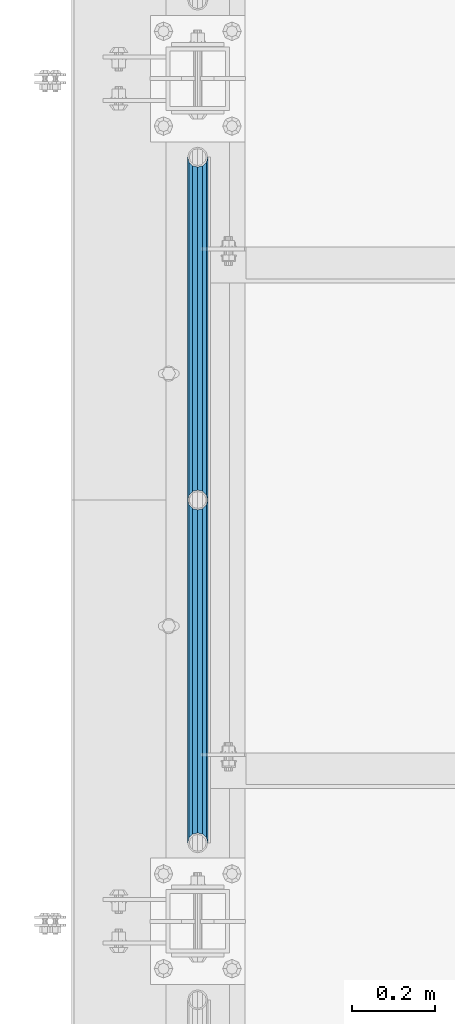
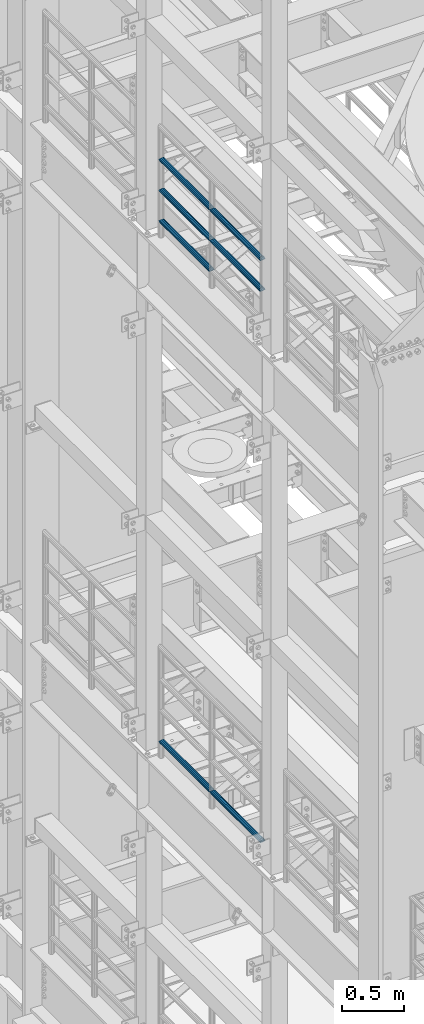
# One storey, part 1227 of 1876: 7 beams, 2 elements without a shape of their own.
"""IFC2X3 building model written with IfcOpenShell, lengths in millimetres."""

from ifc_helpers import new_model, si_unit, frame, origin_with_axes, place, context, subcontext, project, spatial, faceted_brep, material, type_object, element, aggregate, save


model = new_model("IFC2X3")

# Units and contexts
model_context = context("Model", 3, precision=1e-05, world=origin_with_axes())
body_context = subcontext(model_context, "Body", "Model", "MODEL_VIEW")
ifc_project = project(units=[si_unit("LENGTHUNIT", "METRE", prefix="MILLI"), si_unit("AREAUNIT", "SQUARE_METRE"), si_unit("VOLUMEUNIT", "CUBIC_METRE"), si_unit("MASSUNIT", "GRAM", prefix="KILO"), si_unit("TIMEUNIT", "SECOND"), si_unit("PLANEANGLEUNIT", "RADIAN"), si_unit("SOLIDANGLEUNIT", "STERADIAN"), si_unit("THERMODYNAMICTEMPERATUREUNIT", "DEGREE_CELSIUS"), si_unit("LUMINOUSINTENSITYUNIT", "LUMEN")], contexts=[model_context])

# Site, building, storey
site_placement = place(None, origin_with_axes())
site = spatial("IfcSite", under=ifc_project, at=site_placement, CompositionType="ELEMENT")
building_placement = place(site_placement, origin_with_axes())
building = spatial("IfcBuilding", under=site, at=building_placement, Name="Undefined", CompositionType="ELEMENT")
storey_placement = place(building_placement, origin_with_axes())
storey = spatial("IfcBuildingStorey", under=building, at=storey_placement, Name="Undefined", CompositionType="ELEMENT", Elevation=0.0)

# Assembly, beams
assembly_1_placement = place(storey_placement, origin_with_axes())
assembly_1 = element("IfcElementAssembly", 1, at=assembly_1_placement, inside=storey, Name="RAIL", AssemblyPlace="NOTDEFINED", PredefinedType="RIGID_FRAME")
ifc_material = material()
beam_type = type_object("IfcBeamType", Name="PIPE1-1/2SCH40", PredefinedType="NOTDEFINED")
beam_1_placement = place(assembly_1_placement, frame((-1.81898940354586e-12, -697.230000000001, 13471.525), z_axis=(0.0, 0.0, 1.0), x_axis=(0.0, -1.0, 0.0)))
beam_1 = element("IfcBeam", 2, at=beam_1_placement, type_object=beam_type, material=ifc_material, Name="RAIL", ObjectType="PIPE1-1/2SCH40", context=body_context, shape_type="Brep", body=[
    faceted_brep([(805.872807006681, -12.0649999999996, 20.8971929933177), (805.872807006683, -12.0649999999996, 15.8661214311796), (805.379378568819, -10.2235000000001, 17.7076214311819), (802.640000000001, 0.0, 20.4470000000001), (802.640000000001, 0.0, 24.130000000001), (805.379378568819, 10.2235000000001, 17.7076214311819), (805.872807006683, 12.0649999999996, 15.8661214311796), (805.872807006681, 12.0649999999996, 20.8971929933177), (826.77, 24.1300000000001, 0.0), (814.705, 20.8971929933186, 12.0649999999987), (814.705, 20.8971929933186, -12.0649999999987), (811.515428437862, 17.7076214311801, 10.2235000000001), (814.254807006682, 20.4470000000001, 0.0), (811.515428437862, 17.7076214311801, -10.2235000000001), (805.872807006683, 12.0649999999996, -15.8661214311796), (805.872807006681, 12.0649999999996, -20.8971929933177), (805.379378568819, 10.2235000000001, -17.7076214311819), (802.640000000001, 0.0, -20.4470000000001), (802.640000000001, 0.0, -24.130000000001), (805.872807006683, -12.0649999999996, -15.8661214311796), (805.872807006681, -12.0649999999996, -20.8971929933177), (805.379378568819, -10.2235000000001, -17.7076214311819), (826.77, -24.1300000000001, 0.0), (814.705, -20.8971929933186, -12.0649999999987), (814.705, -20.8971929933186, 12.0649999999987), (811.515428437862, -17.7076214311801, -10.2235000000001), (814.254807006682, -20.4470000000001, 0.0), (811.515428437862, -17.7076214311801, 10.2235000000001), (12.0650000000064, -20.8971929933177, -12.0649999999987), (20.8971929933249, -12.0650000000005, -20.8971929933177), (0.0, 24.1299999999992, 0.0), (12.0650000000064, 20.8971929933177, -12.0649999999987), (12.0650000000064, 20.8971929933177, 12.0649999999987), (20.8971929933249, 12.0650000000005, 20.8971929933177), (24.1300000000064, 0.0, 24.130000000001), (20.8971929933249, 12.0650000000005, -20.8971929933177), (24.1300000000063, 0.0, -24.130000000001), (24.1300000000063, 0.0, -20.4470000000001), (20.8971929933249, -12.0650000000005, -15.8661214311796), (21.3906214311868, -10.2235000000001, -17.7076214311819), (21.3906214311868, 10.2235000000001, -17.7076214311819), (20.8971929933249, 12.0650000000005, -15.8661214311796), (15.2545715621445, 17.7076214311801, -10.2235000000001), (12.5151929933249, 20.4470000000001, 0.0), (15.2545715621445, 17.7076214311801, 10.2235000000001), (20.8971929933249, 12.0650000000005, 15.8661214311796), (21.3906214311868, 10.2235000000001, 17.7076214311819), (24.1300000000064, 0.0, 20.4470000000001), (21.3906214311868, -10.2235000000001, 17.7076214311819), (20.8971929933249, -12.0650000000005, 15.8661214311796), (20.8971929933249, -12.0650000000005, 20.8971929933177), (12.0650000000064, -20.8971929933177, 12.0649999999987), (0.0, -24.1299999999992, 0.0), (15.2545715621445, -17.7076214311801, 10.2235000000001), (12.5151929933249, -20.4470000000001, 0.0), (15.2545715621445, -17.7076214311801, -10.2235000000001)], [[[0, 1, 2, 3, 4]], [[4, 3, 5, 6, 7]], [[8, 9, 10]], [[7, 6, 11, 12, 13, 14, 15, 10, 9]], [[16, 17, 18, 15, 14]], [[19, 20, 18, 17, 21]], [[22, 23, 24]], [[24, 23, 20, 19, 25, 26, 27, 1, 0]], [[28, 29, 20, 23]], [[30, 31, 32]], [[33, 34, 4, 7]], [[32, 33, 7, 9]], [[30, 32, 9, 8]], [[31, 30, 8, 10]], [[35, 31, 10, 15]], [[36, 35, 15, 18]], [[29, 36, 18, 20]], [[37, 36, 29, 38, 39]], [[40, 41, 35, 36, 37]], [[32, 31, 35, 41, 42, 43, 44, 45, 33]], [[33, 45, 46, 47, 34]], [[34, 47, 48, 49, 50]], [[34, 50, 0, 4]], [[50, 51, 24, 0]], [[51, 52, 22, 24]], [[52, 28, 23, 22]], [[51, 28, 52]], [[50, 49, 53, 54, 55, 38, 29, 28, 51]], [[55, 54, 26, 25]], [[21, 39, 38, 55, 25, 19]], [[37, 39, 21, 17]], [[40, 37, 17, 16]], [[42, 41, 40, 16, 14, 13]], [[43, 42, 13, 12]], [[44, 43, 12, 11]], [[5, 46, 45, 44, 11, 6]], [[47, 46, 5, 3]], [[48, 47, 3, 2]], [[53, 49, 48, 2, 1, 27]], [[54, 53, 27, 26]]]),
])
beam_2_placement = place(assembly_1_placement, frame((-1.81898940354586e-12, -2350.77, 13776.325), z_axis=(0.0, 0.0, -1.0), x_axis=(0.0, 1.0, 0.0)))
beam_2 = element("IfcBeam", 3, at=beam_2_placement, type_object=beam_type, material=ifc_material, Name="RAIL", ObjectType="PIPE1-1/2SCH40", context=body_context, shape_type="Brep", body=[
    faceted_brep([(0.0, 24.1299999999992, 0.0), (12.0650000000064, 20.8971929933177, -12.0649999999987), (12.0650000000064, 20.8971929933177, 12.0649999999987), (12.0650000000064, -20.8971929933177, 12.0649999999987), (12.0650000000064, -20.8971929933177, -12.0649999999987), (0.0, -24.1299999999992, 0.0), (20.8971929933249, -12.0650000000005, 20.8971929933177), (20.8971929933249, -12.0650000000005, 15.8661214311796), (15.2545715621445, -17.7076214311801, 10.2235000000001), (12.5151929933249, -20.4470000000001, 0.0), (15.2545715621445, -17.7076214311801, -10.2235000000001), (20.8971929933249, -12.0650000000005, -15.8661214311796), (20.8971929933249, -12.0650000000005, -20.8971929933177), (24.1300000000063, 0.0, -20.4470000000001), (24.1300000000063, 0.0, -24.130000000001), (21.3906214311868, -10.2235000000001, -17.7076214311819), (21.3906214311868, 10.2235000000001, -17.7076214311819), (20.8971929933249, 12.0650000000005, -15.8661214311796), (20.8971929933249, 12.0650000000005, -20.8971929933177), (15.2545715621445, 17.7076214311801, -10.2235000000001), (12.5151929933249, 20.4470000000001, 0.0), (15.2545715621445, 17.7076214311801, 10.2235000000001), (20.8971929933249, 12.0650000000005, 15.8661214311796), (20.8971929933249, 12.0650000000005, 20.8971929933177), (21.3906214311868, 10.2235000000001, 17.7076214311819), (24.1300000000064, 0.0, 20.4470000000001), (24.1300000000064, 0.0, 24.130000000001), (21.3906214311868, -10.2235000000001, 17.7076214311819), (826.77, 24.1300000000001, 0.0), (814.705, 20.8971929933186, -12.0649999999987), (805.872807006681, 12.0649999999996, -20.8971929933177), (826.77, -24.1300000000001, 0.0), (814.705, -20.8971929933186, -12.0649999999987), (814.705, -20.8971929933186, 12.0649999999987), (805.872807006681, -12.0649999999996, 20.8971929933177), (805.872807006681, -12.0649999999996, -20.8971929933177), (802.640000000001, 0.0, -24.130000000001), (805.379378568819, 10.2235000000001, -17.7076214311819), (802.640000000001, 0.0, -20.4470000000001), (805.872807006683, 12.0649999999996, -15.8661214311796), (805.872807006683, -12.0649999999996, -15.8661214311796), (805.379378568819, -10.2235000000001, -17.7076214311819), (811.515428437862, -17.7076214311801, -10.2235000000001), (814.254807006682, -20.4470000000001, 0.0), (811.515428437862, -17.7076214311801, 10.2235000000001), (805.872807006683, -12.0649999999996, 15.8661214311796), (805.379378568819, -10.2235000000001, 17.7076214311819), (802.640000000001, 0.0, 20.4470000000001), (802.640000000001, 0.0, 24.130000000001), (805.872807006681, 12.0649999999996, 20.8971929933177), (814.705, 20.8971929933186, 12.0649999999987), (805.872807006683, 12.0649999999996, 15.8661214311796), (811.515428437862, 17.7076214311801, 10.2235000000001), (814.254807006682, 20.4470000000001, 0.0), (811.515428437862, 17.7076214311801, -10.2235000000001), (805.379378568819, 10.2235000000001, 17.7076214311819)], [[[0, 1, 2]], [[3, 4, 5]], [[6, 7, 8, 9, 10, 11, 12, 4, 3]], [[13, 14, 12, 11, 15]], [[16, 17, 18, 14, 13]], [[2, 1, 18, 17, 19, 20, 21, 22, 23]], [[23, 22, 24, 25, 26]], [[26, 25, 27, 7, 6]], [[1, 0, 28, 29]], [[18, 1, 29, 30]], [[31, 32, 33]], [[6, 3, 33, 34]], [[3, 5, 31, 33]], [[5, 4, 32, 31]], [[4, 12, 35, 32]], [[12, 14, 36, 35]], [[14, 18, 30, 36]], [[37, 38, 36, 30, 39]], [[40, 35, 36, 38, 41]], [[33, 32, 35, 40, 42, 43, 44, 45, 34]], [[34, 45, 46, 47, 48]], [[26, 6, 34, 48]], [[2, 23, 49, 50]], [[23, 26, 48, 49]], [[0, 2, 50, 28]], [[28, 50, 29]], [[49, 51, 52, 53, 54, 39, 30, 29, 50]], [[48, 47, 55, 51, 49]], [[25, 24, 55, 47]], [[55, 24, 22, 21, 52, 51]], [[21, 20, 53, 52]], [[20, 19, 54, 53]], [[19, 17, 16, 37, 39, 54]], [[16, 13, 38, 37]], [[13, 15, 41, 38]], [[41, 15, 11, 10, 42, 40]], [[10, 9, 43, 42]], [[9, 8, 44, 43]], [[8, 7, 27, 46, 45, 44]], [[27, 25, 47, 46]]]),
])
beam_3_placement = place(assembly_1_placement, frame((-1.81898940354586e-12, -1524.0, 13776.325), z_axis=(0.0, 0.0, -1.0), x_axis=(0.0, 1.0, 0.0)))
beam_3 = element("IfcBeam", 4, at=beam_3_placement, type_object=beam_type, material=ifc_material, Name="RAIL", ObjectType="PIPE1-1/2SCH40", context=body_context, shape_type="Brep", body=[
    faceted_brep([(0.0, 24.1299999999992, 0.0), (12.0650000000064, 20.8971929933177, -12.0649999999987), (12.0650000000064, 20.8971929933177, 12.0649999999987), (12.0650000000064, -20.8971929933177, 12.0649999999987), (12.0650000000064, -20.8971929933177, -12.0649999999987), (0.0, -24.1299999999992, 0.0), (20.8971929933249, -12.0650000000005, 20.8971929933177), (20.8971929933249, -12.0650000000005, 15.8661214311796), (15.2545715621445, -17.7076214311801, 10.2235000000001), (12.5151929933249, -20.4470000000001, 0.0), (15.2545715621445, -17.7076214311801, -10.2235000000001), (20.8971929933249, -12.0650000000005, -15.8661214311796), (20.8971929933249, -12.0650000000005, -20.8971929933177), (24.1300000000063, 0.0, -20.4470000000001), (24.1300000000063, 0.0, -24.130000000001), (21.3906214311868, -10.2235000000001, -17.7076214311819), (21.3906214311868, 10.2235000000001, -17.7076214311819), (20.8971929933249, 12.0650000000005, -15.8661214311796), (20.8971929933249, 12.0650000000005, -20.8971929933177), (15.2545715621445, 17.7076214311801, -10.2235000000001), (12.5151929933249, 20.4470000000001, 0.0), (15.2545715621445, 17.7076214311801, 10.2235000000001), (20.8971929933249, 12.0650000000005, 15.8661214311796), (20.8971929933249, 12.0650000000005, 20.8971929933177), (21.3906214311868, 10.2235000000001, 17.7076214311819), (24.1300000000064, 0.0, 20.4470000000001), (24.1300000000064, 0.0, 24.130000000001), (21.3906214311868, -10.2235000000001, 17.7076214311819), (826.77, 24.1300000000001, 0.0), (814.705, 20.8971929933186, -12.0649999999987), (805.872807006681, 12.0649999999996, -20.8971929933177), (826.77, -24.1300000000001, 0.0), (814.705, -20.8971929933186, -12.0649999999987), (814.705, -20.8971929933186, 12.0649999999987), (805.872807006681, -12.0649999999996, 20.8971929933177), (805.872807006681, -12.0649999999996, -20.8971929933177), (802.640000000001, 0.0, -24.130000000001), (805.379378568819, 10.2235000000001, -17.7076214311819), (802.640000000001, 0.0, -20.4470000000001), (805.872807006683, 12.0649999999996, -15.8661214311796), (805.872807006683, -12.0649999999996, -15.8661214311796), (805.379378568819, -10.2235000000001, -17.7076214311819), (811.515428437862, -17.7076214311801, -10.2235000000001), (814.254807006682, -20.4470000000001, 0.0), (811.515428437862, -17.7076214311801, 10.2235000000001), (805.872807006683, -12.0649999999996, 15.8661214311796), (805.379378568819, -10.2235000000001, 17.7076214311819), (802.640000000001, 0.0, 20.4470000000001), (802.640000000001, 0.0, 24.130000000001), (805.872807006681, 12.0649999999996, 20.8971929933177), (814.705, 20.8971929933186, 12.0649999999987), (805.872807006683, 12.0649999999996, 15.8661214311796), (811.515428437862, 17.7076214311801, 10.2235000000001), (814.254807006682, 20.4470000000001, 0.0), (811.515428437862, 17.7076214311801, -10.2235000000001), (805.379378568819, 10.2235000000001, 17.7076214311819)], [[[0, 1, 2]], [[3, 4, 5]], [[6, 7, 8, 9, 10, 11, 12, 4, 3]], [[13, 14, 12, 11, 15]], [[16, 17, 18, 14, 13]], [[2, 1, 18, 17, 19, 20, 21, 22, 23]], [[23, 22, 24, 25, 26]], [[26, 25, 27, 7, 6]], [[1, 0, 28, 29]], [[18, 1, 29, 30]], [[31, 32, 33]], [[6, 3, 33, 34]], [[3, 5, 31, 33]], [[5, 4, 32, 31]], [[4, 12, 35, 32]], [[12, 14, 36, 35]], [[14, 18, 30, 36]], [[37, 38, 36, 30, 39]], [[40, 35, 36, 38, 41]], [[33, 32, 35, 40, 42, 43, 44, 45, 34]], [[34, 45, 46, 47, 48]], [[26, 6, 34, 48]], [[2, 23, 49, 50]], [[23, 26, 48, 49]], [[0, 2, 50, 28]], [[28, 50, 29]], [[49, 51, 52, 53, 54, 39, 30, 29, 50]], [[48, 47, 55, 51, 49]], [[25, 24, 55, 47]], [[55, 24, 22, 21, 52, 51]], [[21, 20, 53, 52]], [[20, 19, 54, 53]], [[19, 17, 16, 37, 39, 54]], [[16, 13, 38, 37]], [[13, 15, 41, 38]], [[41, 15, 11, 10, 42, 40]], [[10, 9, 43, 42]], [[9, 8, 44, 43]], [[8, 7, 27, 46, 45, 44]], [[27, 25, 47, 46]]]),
])
beam_4_placement = place(assembly_1_placement, frame((-1.81898940354586e-12, -2350.77, 14081.125), z_axis=(0.0, 0.0, -1.0), x_axis=(0.0, 1.0, 0.0)))
beam_4 = element("IfcBeam", 5, at=beam_4_placement, type_object=beam_type, material=ifc_material, Name="RAIL", ObjectType="PIPE1-1/2SCH40", context=body_context, shape_type="Brep", body=[
    faceted_brep([(0.0, 24.1299999999992, 0.0), (12.0650000000064, 20.8971929933177, -12.0649999999987), (12.0650000000064, 20.8971929933177, 12.0649999999987), (12.0650000000064, -20.8971929933177, 12.0649999999987), (12.0650000000064, -20.8971929933177, -12.0649999999987), (0.0, -24.1299999999992, 0.0), (20.8971929933249, -12.0650000000005, 20.8971929933177), (20.8971929933249, -12.0650000000005, 15.8661214311796), (15.2545715621445, -17.7076214311801, 10.2235000000001), (12.5151929933249, -20.4470000000001, 0.0), (15.2545715621445, -17.7076214311801, -10.2235000000001), (20.8971929933249, -12.0650000000005, -15.8661214311796), (20.8971929933249, -12.0650000000005, -20.8971929933177), (24.1300000000063, 0.0, -20.4470000000001), (24.1300000000063, 0.0, -24.130000000001), (21.3906214311868, -10.2235000000001, -17.7076214311819), (21.3906214311868, 10.2235000000001, -17.7076214311819), (20.8971929933249, 12.0650000000005, -15.8661214311796), (20.8971929933249, 12.0650000000005, -20.8971929933177), (15.2545715621445, 17.7076214311801, -10.2235000000001), (12.5151929933249, 20.4470000000001, 0.0), (15.2545715621445, 17.7076214311801, 10.2235000000001), (20.8971929933249, 12.0650000000005, 15.8661214311796), (20.8971929933249, 12.0650000000005, 20.8971929933177), (21.3906214311868, 10.2235000000001, 17.7076214311819), (24.1300000000064, 0.0, 20.4470000000001), (24.1300000000064, 0.0, 24.130000000001), (21.3906214311868, -10.2235000000001, 17.7076214311819), (826.77, 24.1300000000001, 0.0), (814.705, 20.8971929933186, -12.0649999999987), (805.872807006681, 12.0649999999996, -20.8971929933177), (826.77, -24.1300000000001, 0.0), (814.705, -20.8971929933186, -12.0649999999987), (814.705, -20.8971929933186, 12.0649999999987), (805.872807006681, -12.0649999999996, 20.8971929933177), (805.872807006681, -12.0649999999996, -20.8971929933177), (802.640000000001, 0.0, -24.130000000001), (805.379378568819, 10.2235000000001, -17.7076214311819), (802.640000000001, 0.0, -20.4470000000001), (805.872807006683, 12.0649999999996, -15.8661214311796), (805.872807006683, -12.0649999999996, -15.8661214311796), (805.379378568819, -10.2235000000001, -17.7076214311819), (811.515428437862, -17.7076214311801, -10.2235000000001), (814.254807006682, -20.4470000000001, 0.0), (811.515428437862, -17.7076214311801, 10.2235000000001), (805.872807006683, -12.0649999999996, 15.8661214311796), (805.379378568819, -10.2235000000001, 17.7076214311819), (802.640000000001, 0.0, 20.4470000000001), (802.640000000001, 0.0, 24.130000000001), (805.872807006681, 12.0649999999996, 20.8971929933177), (814.705, 20.8971929933186, 12.0649999999987), (805.872807006683, 12.0649999999996, 15.8661214311796), (811.515428437862, 17.7076214311801, 10.2235000000001), (814.254807006682, 20.4470000000001, 0.0), (811.515428437862, 17.7076214311801, -10.2235000000001), (805.379378568819, 10.2235000000001, 17.7076214311819)], [[[0, 1, 2]], [[3, 4, 5]], [[6, 7, 8, 9, 10, 11, 12, 4, 3]], [[13, 14, 12, 11, 15]], [[16, 17, 18, 14, 13]], [[2, 1, 18, 17, 19, 20, 21, 22, 23]], [[23, 22, 24, 25, 26]], [[26, 25, 27, 7, 6]], [[1, 0, 28, 29]], [[18, 1, 29, 30]], [[31, 32, 33]], [[6, 3, 33, 34]], [[3, 5, 31, 33]], [[5, 4, 32, 31]], [[4, 12, 35, 32]], [[12, 14, 36, 35]], [[14, 18, 30, 36]], [[37, 38, 36, 30, 39]], [[40, 35, 36, 38, 41]], [[33, 32, 35, 40, 42, 43, 44, 45, 34]], [[34, 45, 46, 47, 48]], [[26, 6, 34, 48]], [[2, 23, 49, 50]], [[23, 26, 48, 49]], [[0, 2, 50, 28]], [[28, 50, 29]], [[49, 51, 52, 53, 54, 39, 30, 29, 50]], [[48, 47, 55, 51, 49]], [[25, 24, 55, 47]], [[55, 24, 22, 21, 52, 51]], [[21, 20, 53, 52]], [[20, 19, 54, 53]], [[19, 17, 16, 37, 39, 54]], [[16, 13, 38, 37]], [[13, 15, 41, 38]], [[41, 15, 11, 10, 42, 40]], [[10, 9, 43, 42]], [[9, 8, 44, 43]], [[8, 7, 27, 46, 45, 44]], [[27, 25, 47, 46]]]),
])
beam_5_placement = place(assembly_1_placement, frame((-1.81898940354586e-12, -1524.0, 14081.125), z_axis=(0.0, 0.0, -1.0), x_axis=(0.0, 1.0, 0.0)))
beam_5 = element("IfcBeam", 6, at=beam_5_placement, type_object=beam_type, material=ifc_material, Name="RAIL", ObjectType="PIPE1-1/2SCH40", context=body_context, shape_type="Brep", body=[
    faceted_brep([(0.0, 24.1299999999992, 0.0), (12.0650000000064, 20.8971929933177, -12.0649999999987), (12.0650000000064, 20.8971929933177, 12.0649999999987), (12.0650000000064, -20.8971929933177, 12.0649999999987), (12.0650000000064, -20.8971929933177, -12.0649999999987), (0.0, -24.1299999999992, 0.0), (20.8971929933249, -12.0650000000005, 20.8971929933177), (20.8971929933249, -12.0650000000005, 15.8661214311796), (15.2545715621445, -17.7076214311801, 10.2235000000001), (12.5151929933249, -20.4470000000001, 0.0), (15.2545715621445, -17.7076214311801, -10.2235000000001), (20.8971929933249, -12.0650000000005, -15.8661214311796), (20.8971929933249, -12.0650000000005, -20.8971929933177), (24.1300000000063, 0.0, -20.4470000000001), (24.1300000000063, 0.0, -24.130000000001), (21.3906214311868, -10.2235000000001, -17.7076214311819), (21.3906214311868, 10.2235000000001, -17.7076214311819), (20.8971929933249, 12.0650000000005, -15.8661214311796), (20.8971929933249, 12.0650000000005, -20.8971929933177), (15.2545715621445, 17.7076214311801, -10.2235000000001), (12.5151929933249, 20.4470000000001, 0.0), (15.2545715621445, 17.7076214311801, 10.2235000000001), (20.8971929933249, 12.0650000000005, 15.8661214311796), (20.8971929933249, 12.0650000000005, 20.8971929933177), (21.3906214311868, 10.2235000000001, 17.7076214311819), (24.1300000000064, 0.0, 20.4470000000001), (24.1300000000064, 0.0, 24.130000000001), (21.3906214311868, -10.2235000000001, 17.7076214311819), (826.77, 24.1300000000001, 0.0), (814.705, 20.8971929933186, -12.0649999999987), (805.872807006681, 12.0649999999996, -20.8971929933177), (826.77, -24.1300000000001, 0.0), (814.705, -20.8971929933186, -12.0649999999987), (814.705, -20.8971929933186, 12.0649999999987), (805.872807006681, -12.0649999999996, 20.8971929933177), (805.872807006681, -12.0649999999996, -20.8971929933177), (802.640000000001, 0.0, -24.130000000001), (805.379378568819, 10.2235000000001, -17.7076214311819), (802.640000000001, 0.0, -20.4470000000001), (805.872807006683, 12.0649999999996, -15.8661214311796), (805.872807006683, -12.0649999999996, -15.8661214311796), (805.379378568819, -10.2235000000001, -17.7076214311819), (811.515428437862, -17.7076214311801, -10.2235000000001), (814.254807006682, -20.4470000000001, 0.0), (811.515428437862, -17.7076214311801, 10.2235000000001), (805.872807006683, -12.0649999999996, 15.8661214311796), (805.379378568819, -10.2235000000001, 17.7076214311819), (802.640000000001, 0.0, 20.4470000000001), (802.640000000001, 0.0, 24.130000000001), (805.872807006681, 12.0649999999996, 20.8971929933177), (814.705, 20.8971929933186, 12.0649999999987), (805.872807006683, 12.0649999999996, 15.8661214311796), (811.515428437862, 17.7076214311801, 10.2235000000001), (814.254807006682, 20.4470000000001, 0.0), (811.515428437862, 17.7076214311801, -10.2235000000001), (805.379378568819, 10.2235000000001, 17.7076214311819)], [[[0, 1, 2]], [[3, 4, 5]], [[6, 7, 8, 9, 10, 11, 12, 4, 3]], [[13, 14, 12, 11, 15]], [[16, 17, 18, 14, 13]], [[2, 1, 18, 17, 19, 20, 21, 22, 23]], [[23, 22, 24, 25, 26]], [[26, 25, 27, 7, 6]], [[1, 0, 28, 29]], [[18, 1, 29, 30]], [[31, 32, 33]], [[6, 3, 33, 34]], [[3, 5, 31, 33]], [[5, 4, 32, 31]], [[4, 12, 35, 32]], [[12, 14, 36, 35]], [[14, 18, 30, 36]], [[37, 38, 36, 30, 39]], [[40, 35, 36, 38, 41]], [[33, 32, 35, 40, 42, 43, 44, 45, 34]], [[34, 45, 46, 47, 48]], [[26, 6, 34, 48]], [[2, 23, 49, 50]], [[23, 26, 48, 49]], [[0, 2, 50, 28]], [[28, 50, 29]], [[49, 51, 52, 53, 54, 39, 30, 29, 50]], [[48, 47, 55, 51, 49]], [[25, 24, 55, 47]], [[55, 24, 22, 21, 52, 51]], [[21, 20, 53, 52]], [[20, 19, 54, 53]], [[19, 17, 16, 37, 39, 54]], [[16, 13, 38, 37]], [[13, 15, 41, 38]], [[41, 15, 11, 10, 42, 40]], [[10, 9, 43, 42]], [[9, 8, 44, 43]], [[8, 7, 27, 46, 45, 44]], [[27, 25, 47, 46]]]),
])
aggregate(assembly_1, [beam_1, beam_2, beam_3, beam_4, beam_5])

assembly_2_placement = place(storey_placement, origin_with_axes())
assembly_2 = element("IfcElementAssembly", 7, at=assembly_2_placement, inside=storey, Name="RAIL", AssemblyPlace="NOTDEFINED", PredefinedType="RIGID_FRAME")
beam_6_placement = place(assembly_2_placement, frame((-1.81898940354586e-12, -1524.0, 8315.325), z_axis=(0.0, 0.0, 1.0), x_axis=(0.0, -1.0, 0.0)))
beam_6 = element("IfcBeam", 8, at=beam_6_placement, type_object=beam_type, material=ifc_material, Name="RAIL", ObjectType="PIPE1-1/2SCH40", context=body_context, shape_type="Brep", body=[
    faceted_brep([(805.872807006681, -12.0649999999996, 20.8971929933177), (805.872807006683, -12.0649999999996, 15.8661214311796), (805.379378568819, -10.2235000000001, 17.7076214311819), (802.640000000001, 0.0, 20.4470000000001), (802.640000000001, 0.0, 24.130000000001), (805.379378568819, 10.2235000000001, 17.7076214311819), (805.872807006683, 12.0649999999996, 15.8661214311796), (805.872807006681, 12.0649999999996, 20.8971929933177), (826.77, 24.1300000000001, 0.0), (814.705, 20.8971929933186, 12.0649999999987), (814.705, 20.8971929933186, -12.0649999999987), (811.515428437862, 17.7076214311801, 10.2235000000001), (814.254807006682, 20.4470000000001, 0.0), (811.515428437862, 17.7076214311801, -10.2235000000001), (805.872807006683, 12.0649999999996, -15.8661214311796), (805.872807006681, 12.0649999999996, -20.8971929933177), (805.379378568819, 10.2235000000001, -17.7076214311819), (802.640000000001, 0.0, -20.4470000000001), (802.640000000001, 0.0, -24.130000000001), (805.872807006683, -12.0649999999996, -15.8661214311796), (805.872807006681, -12.0649999999996, -20.8971929933177), (805.379378568819, -10.2235000000001, -17.7076214311819), (826.77, -24.1300000000001, 0.0), (814.705, -20.8971929933186, -12.0649999999987), (814.705, -20.8971929933186, 12.0649999999987), (811.515428437862, -17.7076214311801, -10.2235000000001), (814.254807006682, -20.4470000000001, 0.0), (811.515428437862, -17.7076214311801, 10.2235000000001), (12.0650000000064, -20.8971929933177, -12.0649999999987), (20.8971929933249, -12.0650000000005, -20.8971929933177), (0.0, 24.1299999999992, 0.0), (12.0650000000064, 20.8971929933177, -12.0649999999987), (12.0650000000064, 20.8971929933177, 12.0649999999987), (20.8971929933249, 12.0650000000005, 20.8971929933177), (24.1300000000064, 0.0, 24.130000000001), (20.8971929933249, 12.0650000000005, -20.8971929933177), (24.1300000000063, 0.0, -24.130000000001), (24.1300000000063, 0.0, -20.4470000000001), (20.8971929933249, -12.0650000000005, -15.8661214311796), (21.3906214311868, -10.2235000000001, -17.7076214311819), (21.3906214311868, 10.2235000000001, -17.7076214311819), (20.8971929933249, 12.0650000000005, -15.8661214311796), (15.2545715621445, 17.7076214311801, -10.2235000000001), (12.5151929933249, 20.4470000000001, 0.0), (15.2545715621445, 17.7076214311801, 10.2235000000001), (20.8971929933249, 12.0650000000005, 15.8661214311796), (21.3906214311868, 10.2235000000001, 17.7076214311819), (24.1300000000064, 0.0, 20.4470000000001), (21.3906214311868, -10.2235000000001, 17.7076214311819), (20.8971929933249, -12.0650000000005, 15.8661214311796), (20.8971929933249, -12.0650000000005, 20.8971929933177), (12.0650000000064, -20.8971929933177, 12.0649999999987), (0.0, -24.1299999999992, 0.0), (15.2545715621445, -17.7076214311801, 10.2235000000001), (12.5151929933249, -20.4470000000001, 0.0), (15.2545715621445, -17.7076214311801, -10.2235000000001)], [[[0, 1, 2, 3, 4]], [[4, 3, 5, 6, 7]], [[8, 9, 10]], [[7, 6, 11, 12, 13, 14, 15, 10, 9]], [[16, 17, 18, 15, 14]], [[19, 20, 18, 17, 21]], [[22, 23, 24]], [[24, 23, 20, 19, 25, 26, 27, 1, 0]], [[28, 29, 20, 23]], [[30, 31, 32]], [[33, 34, 4, 7]], [[32, 33, 7, 9]], [[30, 32, 9, 8]], [[31, 30, 8, 10]], [[35, 31, 10, 15]], [[36, 35, 15, 18]], [[29, 36, 18, 20]], [[37, 36, 29, 38, 39]], [[40, 41, 35, 36, 37]], [[32, 31, 35, 41, 42, 43, 44, 45, 33]], [[33, 45, 46, 47, 34]], [[34, 47, 48, 49, 50]], [[34, 50, 0, 4]], [[50, 51, 24, 0]], [[51, 52, 22, 24]], [[52, 28, 23, 22]], [[51, 28, 52]], [[50, 49, 53, 54, 55, 38, 29, 28, 51]], [[55, 54, 26, 25]], [[21, 39, 38, 55, 25, 19]], [[37, 39, 21, 17]], [[40, 37, 17, 16]], [[42, 41, 40, 16, 14, 13]], [[43, 42, 13, 12]], [[44, 43, 12, 11]], [[5, 46, 45, 44, 11, 6]], [[47, 46, 5, 3]], [[48, 47, 3, 2]], [[53, 49, 48, 2, 1, 27]], [[54, 53, 27, 26]]]),
])
beam_7_placement = place(assembly_2_placement, frame((-1.81898940354586e-12, -697.230000000001, 8315.325), z_axis=(0.0, 0.0, 1.0), x_axis=(0.0, -1.0, 0.0)))
beam_7 = element("IfcBeam", 9, at=beam_7_placement, type_object=beam_type, material=ifc_material, Name="RAIL", ObjectType="PIPE1-1/2SCH40", context=body_context, shape_type="Brep", body=[
    faceted_brep([(805.872807006681, -12.0649999999996, 20.8971929933177), (805.872807006683, -12.0649999999996, 15.8661214311796), (805.379378568819, -10.2235000000001, 17.7076214311819), (802.640000000001, 0.0, 20.4470000000001), (802.640000000001, 0.0, 24.130000000001), (805.379378568819, 10.2235000000001, 17.7076214311819), (805.872807006683, 12.0649999999996, 15.8661214311796), (805.872807006681, 12.0649999999996, 20.8971929933177), (826.77, 24.1300000000001, 0.0), (814.705, 20.8971929933186, 12.0649999999987), (814.705, 20.8971929933186, -12.0649999999987), (811.515428437862, 17.7076214311801, 10.2235000000001), (814.254807006682, 20.4470000000001, 0.0), (811.515428437862, 17.7076214311801, -10.2235000000001), (805.872807006683, 12.0649999999996, -15.8661214311796), (805.872807006681, 12.0649999999996, -20.8971929933177), (805.379378568819, 10.2235000000001, -17.7076214311819), (802.640000000001, 0.0, -20.4470000000001), (802.640000000001, 0.0, -24.130000000001), (805.872807006683, -12.0649999999996, -15.8661214311796), (805.872807006681, -12.0649999999996, -20.8971929933177), (805.379378568819, -10.2235000000001, -17.7076214311819), (826.77, -24.1300000000001, 0.0), (814.705, -20.8971929933186, -12.0649999999987), (814.705, -20.8971929933186, 12.0649999999987), (811.515428437862, -17.7076214311801, -10.2235000000001), (814.254807006682, -20.4470000000001, 0.0), (811.515428437862, -17.7076214311801, 10.2235000000001), (12.0650000000064, -20.8971929933177, -12.0649999999987), (20.8971929933249, -12.0650000000005, -20.8971929933177), (0.0, 24.1299999999992, 0.0), (12.0650000000064, 20.8971929933177, -12.0649999999987), (12.0650000000064, 20.8971929933177, 12.0649999999987), (20.8971929933249, 12.0650000000005, 20.8971929933177), (24.1300000000064, 0.0, 24.130000000001), (20.8971929933249, 12.0650000000005, -20.8971929933177), (24.1300000000063, 0.0, -24.130000000001), (24.1300000000063, 0.0, -20.4470000000001), (20.8971929933249, -12.0650000000005, -15.8661214311796), (21.3906214311868, -10.2235000000001, -17.7076214311819), (21.3906214311868, 10.2235000000001, -17.7076214311819), (20.8971929933249, 12.0650000000005, -15.8661214311796), (15.2545715621445, 17.7076214311801, -10.2235000000001), (12.5151929933249, 20.4470000000001, 0.0), (15.2545715621445, 17.7076214311801, 10.2235000000001), (20.8971929933249, 12.0650000000005, 15.8661214311796), (21.3906214311868, 10.2235000000001, 17.7076214311819), (24.1300000000064, 0.0, 20.4470000000001), (21.3906214311868, -10.2235000000001, 17.7076214311819), (20.8971929933249, -12.0650000000005, 15.8661214311796), (20.8971929933249, -12.0650000000005, 20.8971929933177), (12.0650000000064, -20.8971929933177, 12.0649999999987), (0.0, -24.1299999999992, 0.0), (15.2545715621445, -17.7076214311801, 10.2235000000001), (12.5151929933249, -20.4470000000001, 0.0), (15.2545715621445, -17.7076214311801, -10.2235000000001)], [[[0, 1, 2, 3, 4]], [[4, 3, 5, 6, 7]], [[8, 9, 10]], [[7, 6, 11, 12, 13, 14, 15, 10, 9]], [[16, 17, 18, 15, 14]], [[19, 20, 18, 17, 21]], [[22, 23, 24]], [[24, 23, 20, 19, 25, 26, 27, 1, 0]], [[28, 29, 20, 23]], [[30, 31, 32]], [[33, 34, 4, 7]], [[32, 33, 7, 9]], [[30, 32, 9, 8]], [[31, 30, 8, 10]], [[35, 31, 10, 15]], [[36, 35, 15, 18]], [[29, 36, 18, 20]], [[37, 36, 29, 38, 39]], [[40, 41, 35, 36, 37]], [[32, 31, 35, 41, 42, 43, 44, 45, 33]], [[33, 45, 46, 47, 34]], [[34, 47, 48, 49, 50]], [[34, 50, 0, 4]], [[50, 51, 24, 0]], [[51, 52, 22, 24]], [[52, 28, 23, 22]], [[51, 28, 52]], [[50, 49, 53, 54, 55, 38, 29, 28, 51]], [[55, 54, 26, 25]], [[21, 39, 38, 55, 25, 19]], [[37, 39, 21, 17]], [[40, 37, 17, 16]], [[42, 41, 40, 16, 14, 13]], [[43, 42, 13, 12]], [[44, 43, 12, 11]], [[5, 46, 45, 44, 11, 6]], [[47, 46, 5, 3]], [[48, 47, 3, 2]], [[53, 49, 48, 2, 1, 27]], [[54, 53, 27, 26]]]),
])
aggregate(assembly_2, [beam_6, beam_7])

save(model, "model.ifc")
